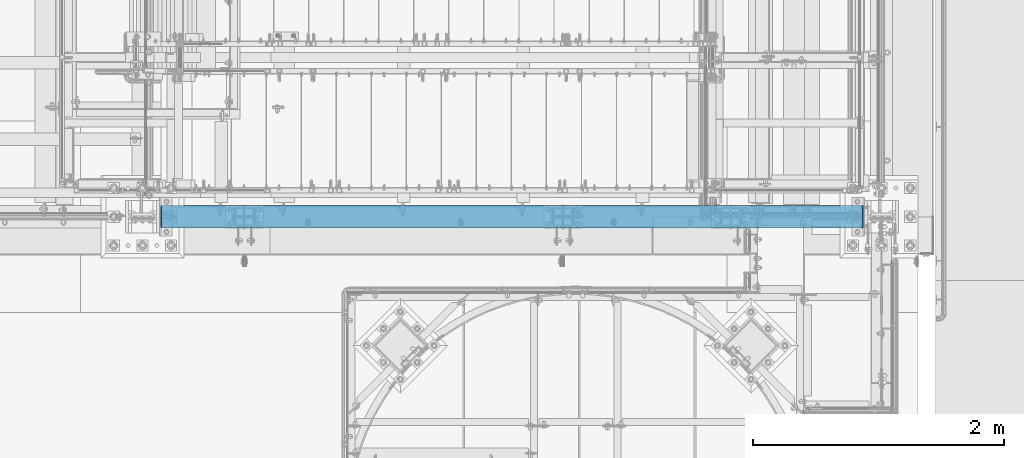
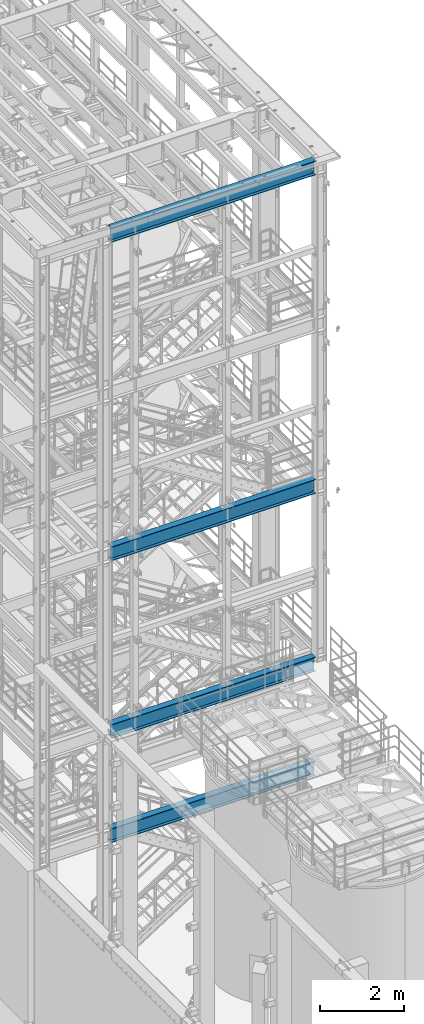
# One storey, part 945 of 1876: 4 beams, 4 elements without a shape of their own.
"""IFC2X3 building model written with IfcOpenShell, lengths in millimetres."""

from ifc_helpers import new_model, si_unit, frame, origin_with_axes, place, context, subcontext, project, spatial, faceted_brep, material, type_object, element, aggregate, save


model = new_model("IFC2X3")

# Units and contexts
model_context = context("Model", 3, precision=1e-05, world=origin_with_axes())
body_context = subcontext(model_context, "Body", "Model", "MODEL_VIEW")
ifc_project = project(units=[si_unit("LENGTHUNIT", "METRE", prefix="MILLI"), si_unit("AREAUNIT", "SQUARE_METRE"), si_unit("VOLUMEUNIT", "CUBIC_METRE"), si_unit("MASSUNIT", "GRAM", prefix="KILO"), si_unit("TIMEUNIT", "SECOND"), si_unit("PLANEANGLEUNIT", "RADIAN"), si_unit("SOLIDANGLEUNIT", "STERADIAN"), si_unit("THERMODYNAMICTEMPERATUREUNIT", "DEGREE_CELSIUS"), si_unit("LUMINOUSINTENSITYUNIT", "LUMEN")], contexts=[model_context])

# Site, building, storey
site_placement = place(None, origin_with_axes())
site = spatial("IfcSite", under=ifc_project, at=site_placement, CompositionType="ELEMENT")
building_placement = place(site_placement, origin_with_axes())
building = spatial("IfcBuilding", under=site, at=building_placement, Name="Undefined", CompositionType="ELEMENT")
storey_placement = place(building_placement, origin_with_axes())
storey = spatial("IfcBuildingStorey", under=building, at=storey_placement, Name="Undefined", CompositionType="ELEMENT", Elevation=0.0)

# Assembly, beam
assembly_1_placement = place(storey_placement, origin_with_axes())
assembly_1 = element("IfcElementAssembly", 1, at=assembly_1_placement, inside=storey, Name="BEAM", AssemblyPlace="NOTDEFINED", PredefinedType="RIGID_FRAME")
ifc_material = material(Name="STEEL/A992")
beam_type = type_object("IfcBeamType", Name="W16X45", PredefinedType="NOTDEFINED")
beam_1_placement = place(assembly_1_placement, frame((1727.2, -7112.0, 13104.8125), z_axis=(0.0, 0.0, 1.0), x_axis=(1.0, 0.0, 0.0)))
beam_1 = element("IfcBeam", 2, at=beam_1_placement, type_object=beam_type, material=ifc_material, Name="BEAM", ObjectType="W16X45", context=body_context, shape_type="Brep", body=[
    faceted_brep([(5748.3375, 4.76249999999982, 161.924999999999), (5738.81249970572, -4.76249999999982, 161.924999999999), (5738.81249970572, -4.76249999999982, -161.924999999999), (5748.3375, 4.76249999999982, -161.924999999999), (144.4625, 88.8999999999996, 190.5), (152.711099599373, 88.8999999999996, 204.787499999999), (5740.08890040063, 88.8999999999996, 204.787499999999), (5748.3375, 88.8999999999996, 190.5), (144.4625, 4.76249999999982, 190.5), (5748.3375, 4.76249999999982, 190.5), (152.711120260645, -88.8999999999996, -190.5), (144.4625, -88.8999999999996, -204.787499999999), (5748.3375, -88.8999999999996, -204.787499999999), (5740.08887973935, -88.8999999999996, -190.5), (144.4625, 88.8999999999996, -204.787499999999), (5748.3375, 88.8999999999996, -204.787499999999), (152.711120260645, 88.8999999999996, -190.5), (5740.08887973935, 88.8999999999996, -190.5), (152.711120260645, 4.76249999999982, -190.5), (5740.08887973935, 4.76249999999982, -190.5), (5696.31330732956, -4.76249999999982, -163.290718362852), (5696.31330732956, 4.76249999999982, -163.290718362852), (5701.22775003691, 4.76249999999982, -161.924999999999), (5701.22775003691, -4.76249999999982, -161.924999999999), (5692.80815489359, -4.76249999999982, -166.996233194965), (5692.80815489359, 4.76249999999982, -166.996233194965), (5691.71744784461, -4.76249999999982, -171.978932453771), (5691.71744784461, 4.76249999999982, -171.978932453771), (5693.35396281357, -4.76249999999982, -176.80995227641), (5693.35396281357, 4.76249999999982, -176.80995227641), (5697.24840454932, -4.76249999999982, -180.103925156887), (5697.24840454932, 4.76249999999982, -180.103925156887), (5718.99349932861, -4.76249999999982, -190.102999496459), (5718.99349932861, 4.76249999999982, -190.102999496459), (5739.85968949887, -4.76249999999982, -190.102999496459), (5739.85968949887, 4.76249999999982, -190.102999496459), (5740.08887973935, -4.76249999999982, -190.5), (152.711120260645, -4.76249999999982, -190.5), (152.940310501126, -4.76249999999982, -190.102999496459), (152.940310501126, 4.76249999999982, -190.102999496459), (173.806500671387, -4.76249999999982, -190.102999496459), (173.806500671387, 4.76249999999982, -190.102999496459), (195.551595450686, -4.76249999999982, -180.103925156884), (195.551595450686, 4.76249999999982, -180.103925156884), (199.446037186428, -4.76249999999982, -176.80995227641), (199.446037186428, 4.76249999999982, -176.80995227641), (201.082552155395, -4.76249999999982, -171.978932453767), (201.082552155395, 4.76249999999982, -171.978932453767), (199.991845106413, -4.76249999999982, -166.996233194965), (199.991845106413, 4.76249999999982, -166.996233194965), (196.486692670442, -4.76249999999982, -163.290718362852), (196.486692670442, 4.76249999999982, -163.290718362852), (191.572249963099, -4.76249999999982, -161.924999999999), (191.572249963099, 4.76249999999982, -161.924999999999), (153.987500294277, -4.76249999999982, -161.924999999996), (144.4625, 4.76249999999982, -161.924999999996), (153.987500294277, -4.7625002942832, 161.925000000003), (144.4625, 4.76249999999982, 161.925000000003), (190.80324988243, -4.76249999999982, 161.924999999999), (190.80324988243, 4.76249999999982, 161.924999999999), (195.717692628333, -4.76249999999982, 163.290718386077), (195.717692628333, 4.76249999999982, 163.290718386077), (199.22284506784, -4.76249999999982, 166.996233274545), (199.22284506784, 4.76249999999982, 166.996233274545), (200.313552067229, -4.76249999999982, 171.978932588601), (200.313552067229, 4.76249999999982, 171.978932588601), (198.677037004441, -4.76249999999982, 176.80995242525), (198.677037004441, 4.76249999999982, 176.80995242525), (194.782595165536, -4.76249999999982, 180.103925250914), (194.782595165536, 4.76249999999982, 180.103925250914), (173.037499237061, -4.76249999999982, 190.102999496463), (173.037499237061, 4.76249999999982, 190.102999496463), (144.4625, -4.76249999999982, 190.102999496463), (144.4625, 4.76249999999982, 190.102999496463), (144.4625, -4.76249999999982, 190.5), (152.711099599373, -88.8999999999996, 204.787499999999), (144.4625, -88.8999999999996, 190.5), (5748.3375, -4.76249999999982, 190.5), (5748.3375, -88.8999999999996, 190.5), (5740.08890040063, -88.8999999999996, 204.787499999999), (5748.3375, -4.76249999999982, 190.102999496459), (5748.3375, 4.76249999999982, 190.102999496459), (5719.76250076294, -4.76249999999982, 190.102999496459), (5719.76250076294, 4.76249999999982, 190.102999496459), (5698.01740483447, -4.76249999999982, 180.103925250914), (5698.01740483447, 4.76249999999982, 180.103925250914), (5694.12296299556, -4.76249999999982, 176.80995242525), (5694.12296299556, 4.76249999999982, 176.80995242525), (5692.48644793277, -4.76249999999982, 171.978932588601), (5692.48644793277, 4.76249999999982, 171.978932588601), (5693.57715493216, -4.76249999999982, 166.996233274542), (5693.57715493216, 4.76249999999982, 166.996233274542), (5697.08230737167, -4.76249999999982, 163.290718386077), (5697.08230737167, 4.76249999999982, 163.290718386077), (5701.99675011757, -4.76249999999982, 161.924999999999), (5701.99675011757, 4.76249999999982, 161.924999999999)], [[[0, 1, 2, 3]], [[4, 5, 6, 7]], [[8, 4, 7, 9]], [[10, 11, 12, 13]], [[11, 14, 15, 12]], [[14, 16, 17, 15]], [[16, 18, 19, 17]], [[20, 21, 22, 23]], [[24, 25, 21, 20]], [[26, 27, 25, 24]], [[28, 29, 27, 26]], [[30, 31, 29, 28]], [[32, 33, 31, 30]], [[33, 32, 34, 35]], [[12, 15, 17, 19, 35, 34, 36, 13]], [[37, 10, 13, 36]], [[38, 39, 18, 16, 14, 11, 10, 37]], [[40, 41, 39, 38]], [[42, 43, 41, 40]], [[44, 45, 43, 42]], [[46, 47, 45, 44]], [[48, 49, 47, 46]], [[50, 51, 49, 48]], [[52, 53, 51, 50]], [[53, 52, 54, 55]], [[56, 57, 55, 54]], [[58, 59, 57, 56]], [[60, 61, 59, 58]], [[62, 63, 61, 60]], [[64, 65, 63, 62]], [[66, 67, 65, 64]], [[68, 69, 67, 66]], [[70, 71, 69, 68]], [[71, 70, 72, 73]], [[73, 72, 74, 8]], [[75, 5, 4, 8, 74, 76]], [[76, 74, 77, 78]], [[75, 76, 78, 79]], [[5, 75, 79, 6]], [[78, 77, 9, 7, 6, 79]], [[80, 81, 9, 77]], [[82, 83, 81, 80]], [[84, 85, 83, 82]], [[86, 87, 85, 84]], [[88, 89, 87, 86]], [[90, 91, 89, 88]], [[92, 93, 91, 90]], [[94, 95, 93, 92]], [[22, 21, 25, 27, 29, 31, 33, 35, 19, 18, 39, 41, 43, 45, 47, 49, 51, 53, 55, 57, 59, 61, 63, 65, 67, 69, 71, 73, 8, 9, 81, 83, 85, 87, 89, 91, 93, 95, 0, 3]], [[23, 22, 3, 2]], [[94, 92, 90, 88, 86, 84, 82, 80, 77, 74, 72, 70, 68, 66, 64, 62, 60, 58, 56, 54, 52, 50, 48, 46, 44, 42, 40, 38, 37, 36, 34, 32, 30, 28, 26, 24, 20, 23, 2, 1]], [[95, 94, 1, 0]]]),
])
aggregate(assembly_1, [beam_1])

assembly_2_placement = place(storey_placement, origin_with_axes())
assembly_2 = element("IfcElementAssembly", 3, at=assembly_2_placement, inside=storey, Name="BEAM", AssemblyPlace="NOTDEFINED", PredefinedType="RIGID_FRAME")
beam_2_placement = place(assembly_2_placement, frame((1727.2, -7112.0, 7948.6125), z_axis=(0.0, 0.0, 1.0), x_axis=(1.0, 0.0, 0.0)))
beam_2 = element("IfcBeam", 4, at=beam_2_placement, type_object=beam_type, material=ifc_material, Name="BEAM", ObjectType="W16X45", context=body_context, shape_type="Brep", body=[
    faceted_brep([(5748.3375, 4.76249999999982, 161.924999999999), (5738.81249970572, -4.76249999999982, 161.924999999999), (5738.81249970572, -4.76249999999982, -161.924999999999), (5748.3375, 4.76249999999982, -161.924999999999), (144.4625, 88.8999999999996, 190.5), (152.711099599373, 88.8999999999996, 204.787499999999), (5740.08890040063, 88.8999999999996, 204.787499999999), (5748.3375, 88.8999999999996, 190.5), (144.4625, 4.76249999999982, 190.5), (5748.3375, 4.76249999999982, 190.5), (152.711120260645, -88.8999999999996, -190.5), (144.4625, -88.8999999999996, -204.787499999999), (5748.3375, -88.8999999999996, -204.787499999999), (5740.08887973935, -88.8999999999996, -190.5), (144.4625, 88.8999999999996, -204.787499999999), (5748.3375, 88.8999999999996, -204.787499999999), (152.711120260645, 88.8999999999996, -190.5), (5740.08887973935, 88.8999999999996, -190.5), (152.711120260645, 4.76249999999982, -190.5), (5740.08887973935, 4.76249999999982, -190.5), (5696.31330732956, -4.76249999999982, -163.290718362852), (5696.31330732956, 4.76249999999982, -163.290718362852), (5701.22775003691, 4.76249999999982, -161.924999999999), (5701.22775003691, -4.76249999999982, -161.924999999999), (5692.80815489359, -4.76249999999982, -166.996233194965), (5692.80815489359, 4.76249999999982, -166.996233194965), (5691.71744784461, -4.76249999999982, -171.978932453771), (5691.71744784461, 4.76249999999982, -171.978932453771), (5693.35396281357, -4.76249999999982, -176.80995227641), (5693.35396281357, 4.76249999999982, -176.80995227641), (5697.24840454932, -4.76249999999982, -180.103925156887), (5697.24840454932, 4.76249999999982, -180.103925156887), (5718.99349932861, -4.76249999999982, -190.102999496459), (5718.99349932861, 4.76249999999982, -190.102999496459), (5739.85968949887, -4.76249999999982, -190.102999496459), (5739.85968949887, 4.76249999999982, -190.102999496459), (5740.08887973935, -4.76249999999982, -190.5), (152.711120260645, -4.76249999999982, -190.5), (152.940310501126, -4.76249999999982, -190.102999496459), (152.940310501126, 4.76249999999982, -190.102999496459), (173.806500671387, -4.76249999999982, -190.102999496459), (173.806500671387, 4.76249999999982, -190.102999496459), (195.551595450686, -4.76249999999982, -180.103925156884), (195.551595450686, 4.76249999999982, -180.103925156884), (199.446037186428, -4.76249999999982, -176.80995227641), (199.446037186428, 4.76249999999982, -176.80995227641), (201.082552155395, -4.76249999999982, -171.978932453767), (201.082552155395, 4.76249999999982, -171.978932453767), (199.991845106413, -4.76249999999982, -166.996233194965), (199.991845106413, 4.76249999999982, -166.996233194965), (196.486692670442, -4.76249999999982, -163.290718362852), (196.486692670442, 4.76249999999982, -163.290718362852), (191.572249963099, -4.76249999999982, -161.924999999999), (191.572249963099, 4.76249999999982, -161.924999999999), (153.987500294277, -4.76249999999982, -161.924999999996), (144.4625, 4.76249999999982, -161.924999999996), (153.987500294277, -4.7625002942832, 161.925000000003), (144.4625, 4.76249999999982, 161.925000000003), (190.80324988243, -4.76249999999982, 161.924999999999), (190.80324988243, 4.76249999999982, 161.924999999999), (195.717692628333, -4.76249999999982, 163.290718386077), (195.717692628333, 4.76249999999982, 163.290718386077), (199.22284506784, -4.76249999999982, 166.996233274545), (199.22284506784, 4.76249999999982, 166.996233274545), (200.313552067229, -4.76249999999982, 171.978932588601), (200.313552067229, 4.76249999999982, 171.978932588601), (198.677037004441, -4.76249999999982, 176.80995242525), (198.677037004441, 4.76249999999982, 176.80995242525), (194.782595165536, -4.76249999999982, 180.103925250914), (194.782595165536, 4.76249999999982, 180.103925250914), (173.037499237061, -4.76249999999982, 190.102999496463), (173.037499237061, 4.76249999999982, 190.102999496463), (144.4625, -4.76249999999982, 190.102999496463), (144.4625, 4.76249999999982, 190.102999496463), (144.4625, -4.76249999999982, 190.5), (152.711099599373, -88.8999999999996, 204.787499999999), (144.4625, -88.8999999999996, 190.5), (5748.3375, -4.76249999999982, 190.5), (5748.3375, -88.8999999999996, 190.5), (5740.08890040063, -88.8999999999996, 204.787499999999), (5748.3375, -4.76249999999982, 190.102999496459), (5748.3375, 4.76249999999982, 190.102999496459), (5719.76250076294, -4.76249999999982, 190.102999496459), (5719.76250076294, 4.76249999999982, 190.102999496459), (5698.01740483447, -4.76249999999982, 180.103925250914), (5698.01740483447, 4.76249999999982, 180.103925250914), (5694.12296299556, -4.76249999999982, 176.80995242525), (5694.12296299556, 4.76249999999982, 176.80995242525), (5692.48644793277, -4.76249999999982, 171.978932588601), (5692.48644793277, 4.76249999999982, 171.978932588601), (5693.57715493216, -4.76249999999982, 166.996233274542), (5693.57715493216, 4.76249999999982, 166.996233274542), (5697.08230737167, -4.76249999999982, 163.290718386077), (5697.08230737167, 4.76249999999982, 163.290718386077), (5701.99675011757, -4.76249999999982, 161.924999999999), (5701.99675011757, 4.76249999999982, 161.924999999999)], [[[0, 1, 2, 3]], [[4, 5, 6, 7]], [[8, 4, 7, 9]], [[10, 11, 12, 13]], [[11, 14, 15, 12]], [[14, 16, 17, 15]], [[16, 18, 19, 17]], [[20, 21, 22, 23]], [[24, 25, 21, 20]], [[26, 27, 25, 24]], [[28, 29, 27, 26]], [[30, 31, 29, 28]], [[32, 33, 31, 30]], [[33, 32, 34, 35]], [[12, 15, 17, 19, 35, 34, 36, 13]], [[37, 10, 13, 36]], [[38, 39, 18, 16, 14, 11, 10, 37]], [[40, 41, 39, 38]], [[42, 43, 41, 40]], [[44, 45, 43, 42]], [[46, 47, 45, 44]], [[48, 49, 47, 46]], [[50, 51, 49, 48]], [[52, 53, 51, 50]], [[53, 52, 54, 55]], [[56, 57, 55, 54]], [[58, 59, 57, 56]], [[60, 61, 59, 58]], [[62, 63, 61, 60]], [[64, 65, 63, 62]], [[66, 67, 65, 64]], [[68, 69, 67, 66]], [[70, 71, 69, 68]], [[71, 70, 72, 73]], [[73, 72, 74, 8]], [[75, 5, 4, 8, 74, 76]], [[76, 74, 77, 78]], [[75, 76, 78, 79]], [[5, 75, 79, 6]], [[78, 77, 9, 7, 6, 79]], [[80, 81, 9, 77]], [[82, 83, 81, 80]], [[84, 85, 83, 82]], [[86, 87, 85, 84]], [[88, 89, 87, 86]], [[90, 91, 89, 88]], [[92, 93, 91, 90]], [[94, 95, 93, 92]], [[22, 21, 25, 27, 29, 31, 33, 35, 19, 18, 39, 41, 43, 45, 47, 49, 51, 53, 55, 57, 59, 61, 63, 65, 67, 69, 71, 73, 8, 9, 81, 83, 85, 87, 89, 91, 93, 95, 0, 3]], [[23, 22, 3, 2]], [[94, 92, 90, 88, 86, 84, 82, 80, 77, 74, 72, 70, 68, 66, 64, 62, 60, 58, 56, 54, 52, 50, 48, 46, 44, 42, 40, 38, 37, 36, 34, 32, 30, 28, 26, 24, 20, 23, 2, 1]], [[95, 94, 1, 0]]]),
])
aggregate(assembly_2, [beam_2])

assembly_3_placement = place(storey_placement, origin_with_axes())
assembly_3 = element("IfcElementAssembly", 5, at=assembly_3_placement, inside=storey, Name="BEAM", AssemblyPlace="NOTDEFINED", PredefinedType="RIGID_FRAME")
beam_3_placement = place(assembly_3_placement, frame((1727.2, -7112.0, 22350.4125), z_axis=(0.0, 0.0, 1.0), x_axis=(1.0, 0.0, 0.0)))
beam_3 = element("IfcBeam", 6, at=beam_3_placement, type_object=beam_type, material=ifc_material, Name="BEAM", ObjectType="W16X45", context=body_context, shape_type="Brep", body=[
    faceted_brep([(5748.3375, 4.76249999999982, 161.924999999999), (5738.81249970572, -4.76249999999982, 161.924999999999), (5738.81249970572, -4.76249999999982, -161.924999999999), (5748.3375, 4.76249999999982, -161.924999999999), (144.4625, 88.8999999999996, 190.5), (152.711099599373, 88.8999999999996, 204.787499999999), (5740.08890040063, 88.8999999999996, 204.787499999999), (5748.3375, 88.8999999999996, 190.5), (144.4625, 4.76249999999982, 190.5), (5748.3375, 4.76249999999982, 190.5), (152.711120260645, -88.8999999999996, -190.5), (144.4625, -88.8999999999996, -204.787499999999), (5748.3375, -88.8999999999996, -204.787499999999), (5740.08887973935, -88.8999999999996, -190.5), (144.4625, 88.8999999999996, -204.787499999999), (5748.3375, 88.8999999999996, -204.787499999999), (152.711120260645, 88.8999999999996, -190.5), (5740.08887973935, 88.8999999999996, -190.5), (152.711120260645, 4.76249999999982, -190.5), (5740.08887973935, 4.76249999999982, -190.5), (5696.31330732956, -4.76249999999982, -163.290718362852), (5696.31330732956, 4.76249999999982, -163.290718362852), (5701.22775003691, 4.76249999999982, -161.924999999999), (5701.22775003691, -4.76249999999982, -161.924999999999), (5692.80815489359, -4.76249999999982, -166.996233194965), (5692.80815489359, 4.76249999999982, -166.996233194965), (5691.71744784461, -4.76249999999982, -171.978932453771), (5691.71744784461, 4.76249999999982, -171.978932453771), (5693.35396281357, -4.76249999999982, -176.80995227641), (5693.35396281357, 4.76249999999982, -176.80995227641), (5697.24840454932, -4.76249999999982, -180.103925156887), (5697.24840454932, 4.76249999999982, -180.103925156887), (5718.99349932861, -4.76249999999982, -190.102999496459), (5718.99349932861, 4.76249999999982, -190.102999496459), (5739.85968949887, -4.76249999999982, -190.102999496459), (5739.85968949887, 4.76249999999982, -190.102999496459), (5740.08887973935, -4.76249999999982, -190.5), (152.711120260645, -4.76249999999982, -190.5), (152.940310501126, -4.76249999999982, -190.102999496459), (152.940310501126, 4.76249999999982, -190.102999496459), (173.806500671387, -4.76249999999982, -190.102999496459), (173.806500671387, 4.76249999999982, -190.102999496459), (195.551595450686, -4.76249999999982, -180.103925156884), (195.551595450686, 4.76249999999982, -180.103925156884), (199.446037186428, -4.76249999999982, -176.80995227641), (199.446037186428, 4.76249999999982, -176.80995227641), (201.082552155395, -4.76249999999982, -171.978932453767), (201.082552155395, 4.76249999999982, -171.978932453767), (199.991845106413, -4.76249999999982, -166.996233194965), (199.991845106413, 4.76249999999982, -166.996233194965), (196.486692670442, -4.76249999999982, -163.290718362852), (196.486692670442, 4.76249999999982, -163.290718362852), (191.572249963099, -4.76249999999982, -161.924999999999), (191.572249963099, 4.76249999999982, -161.924999999999), (153.987500294277, -4.76249999999982, -161.924999999996), (144.4625, 4.76249999999982, -161.924999999996), (153.987500294277, -4.7625002942832, 161.925000000003), (144.4625, 4.76249999999982, 161.925000000003), (190.80324988243, -4.76249999999982, 161.924999999999), (190.80324988243, 4.76249999999982, 161.924999999999), (195.717692628333, -4.76249999999982, 163.290718386077), (195.717692628333, 4.76249999999982, 163.290718386077), (199.22284506784, -4.76249999999982, 166.996233274545), (199.22284506784, 4.76249999999982, 166.996233274545), (200.313552067229, -4.76249999999982, 171.978932588601), (200.313552067229, 4.76249999999982, 171.978932588601), (198.677037004441, -4.76249999999982, 176.80995242525), (198.677037004441, 4.76249999999982, 176.80995242525), (194.782595165536, -4.76249999999982, 180.103925250914), (194.782595165536, 4.76249999999982, 180.103925250914), (173.037499237061, -4.76249999999982, 190.102999496463), (173.037499237061, 4.76249999999982, 190.102999496463), (144.4625, -4.76249999999982, 190.102999496463), (144.4625, 4.76249999999982, 190.102999496463), (144.4625, -4.76249999999982, 190.5), (152.711099599373, -88.8999999999996, 204.787499999999), (144.4625, -88.8999999999996, 190.5), (5748.3375, -4.76249999999982, 190.5), (5748.3375, -88.8999999999996, 190.5), (5740.08890040063, -88.8999999999996, 204.787499999999), (5748.3375, -4.76249999999982, 190.102999496459), (5748.3375, 4.76249999999982, 190.102999496459), (5719.76250076294, -4.76249999999982, 190.102999496459), (5719.76250076294, 4.76249999999982, 190.102999496459), (5698.01740483447, -4.76249999999982, 180.103925250914), (5698.01740483447, 4.76249999999982, 180.103925250914), (5694.12296299556, -4.76249999999982, 176.80995242525), (5694.12296299556, 4.76249999999982, 176.80995242525), (5692.48644793277, -4.76249999999982, 171.978932588601), (5692.48644793277, 4.76249999999982, 171.978932588601), (5693.57715493216, -4.76249999999982, 166.996233274542), (5693.57715493216, 4.76249999999982, 166.996233274542), (5697.08230737167, -4.76249999999982, 163.290718386077), (5697.08230737167, 4.76249999999982, 163.290718386077), (5701.99675011757, -4.76249999999982, 161.924999999999), (5701.99675011757, 4.76249999999982, 161.924999999999)], [[[0, 1, 2, 3]], [[4, 5, 6, 7]], [[8, 4, 7, 9]], [[10, 11, 12, 13]], [[11, 14, 15, 12]], [[14, 16, 17, 15]], [[16, 18, 19, 17]], [[20, 21, 22, 23]], [[24, 25, 21, 20]], [[26, 27, 25, 24]], [[28, 29, 27, 26]], [[30, 31, 29, 28]], [[32, 33, 31, 30]], [[33, 32, 34, 35]], [[12, 15, 17, 19, 35, 34, 36, 13]], [[37, 10, 13, 36]], [[38, 39, 18, 16, 14, 11, 10, 37]], [[40, 41, 39, 38]], [[42, 43, 41, 40]], [[44, 45, 43, 42]], [[46, 47, 45, 44]], [[48, 49, 47, 46]], [[50, 51, 49, 48]], [[52, 53, 51, 50]], [[53, 52, 54, 55]], [[56, 57, 55, 54]], [[58, 59, 57, 56]], [[60, 61, 59, 58]], [[62, 63, 61, 60]], [[64, 65, 63, 62]], [[66, 67, 65, 64]], [[68, 69, 67, 66]], [[70, 71, 69, 68]], [[71, 70, 72, 73]], [[73, 72, 74, 8]], [[75, 5, 4, 8, 74, 76]], [[76, 74, 77, 78]], [[75, 76, 78, 79]], [[5, 75, 79, 6]], [[78, 77, 9, 7, 6, 79]], [[80, 81, 9, 77]], [[82, 83, 81, 80]], [[84, 85, 83, 82]], [[86, 87, 85, 84]], [[88, 89, 87, 86]], [[90, 91, 89, 88]], [[92, 93, 91, 90]], [[94, 95, 93, 92]], [[22, 21, 25, 27, 29, 31, 33, 35, 19, 18, 39, 41, 43, 45, 47, 49, 51, 53, 55, 57, 59, 61, 63, 65, 67, 69, 71, 73, 8, 9, 81, 83, 85, 87, 89, 91, 93, 95, 0, 3]], [[23, 22, 3, 2]], [[94, 92, 90, 88, 86, 84, 82, 80, 77, 74, 72, 70, 68, 66, 64, 62, 60, 58, 56, 54, 52, 50, 48, 46, 44, 42, 40, 38, 37, 36, 34, 32, 30, 28, 26, 24, 20, 23, 2, 1]], [[95, 94, 1, 0]]]),
])
aggregate(assembly_3, [beam_3])

assembly_4_placement = place(storey_placement, origin_with_axes())
assembly_4 = element("IfcElementAssembly", 7, at=assembly_4_placement, inside=storey, Name="BEAM", AssemblyPlace="NOTDEFINED", PredefinedType="RIGID_FRAME")
beam_4_placement = place(assembly_4_placement, frame((1727.2, -7112.0, 4926.0125), z_axis=(0.0, 0.0, 1.0), x_axis=(1.0, 0.0, 0.0)))
beam_4 = element("IfcBeam", 8, at=beam_4_placement, type_object=beam_type, material=ifc_material, Name="BEAM", ObjectType="W16X45", context=body_context, shape_type="Brep", body=[
    faceted_brep([(5748.3375, 4.76249999999982, 161.924999999999), (5738.81249970572, -4.76249999999982, 161.924999999999), (5738.81249970572, -4.76249999999982, -161.924999999999), (5748.3375, 4.76249999999982, -161.924999999999), (144.4625, 88.8999999999996, 190.5), (152.711099599373, 88.8999999999996, 204.787499999999), (5740.08890040063, 88.8999999999996, 204.787499999999), (5748.3375, 88.8999999999996, 190.5), (144.4625, 4.76249999999982, 190.5), (5748.3375, 4.76249999999982, 190.5), (152.711120260645, -88.8999999999996, -190.5), (144.4625, -88.8999999999996, -204.787499999999), (5748.3375, -88.8999999999996, -204.787499999999), (5740.08887973935, -88.8999999999996, -190.5), (144.4625, 88.8999999999996, -204.787499999999), (5748.3375, 88.8999999999996, -204.787499999999), (152.711120260645, 88.8999999999996, -190.5), (5740.08887973935, 88.8999999999996, -190.5), (152.711120260645, 4.76249999999982, -190.5), (5740.08887973935, 4.76249999999982, -190.5), (5696.31330732956, -4.76249999999982, -163.290718362852), (5696.31330732956, 4.76249999999982, -163.290718362852), (5701.22775003691, 4.76249999999982, -161.924999999999), (5701.22775003691, -4.76249999999982, -161.924999999999), (5692.80815489359, -4.76249999999982, -166.996233194965), (5692.80815489359, 4.76249999999982, -166.996233194965), (5691.71744784461, -4.76249999999982, -171.978932453771), (5691.71744784461, 4.76249999999982, -171.978932453771), (5693.35396281357, -4.76249999999982, -176.80995227641), (5693.35396281357, 4.76249999999982, -176.80995227641), (5697.24840454932, -4.76249999999982, -180.103925156887), (5697.24840454932, 4.76249999999982, -180.103925156887), (5718.99349932861, -4.76249999999982, -190.102999496459), (5718.99349932861, 4.76249999999982, -190.102999496459), (5739.85968949887, -4.76249999999982, -190.102999496459), (5739.85968949887, 4.76249999999982, -190.102999496459), (5740.08887973935, -4.76249999999982, -190.5), (152.711120260645, -4.76249999999982, -190.5), (152.940310501126, -4.76249999999982, -190.102999496459), (152.940310501126, 4.76249999999982, -190.102999496459), (173.806500671387, -4.76249999999982, -190.102999496459), (173.806500671387, 4.76249999999982, -190.102999496459), (195.551595450686, -4.76249999999982, -180.103925156884), (195.551595450686, 4.76249999999982, -180.103925156884), (199.446037186428, -4.76249999999982, -176.80995227641), (199.446037186428, 4.76249999999982, -176.80995227641), (201.082552155395, -4.76249999999982, -171.978932453767), (201.082552155395, 4.76249999999982, -171.978932453767), (199.991845106413, -4.76249999999982, -166.996233194965), (199.991845106413, 4.76249999999982, -166.996233194965), (196.486692670442, -4.76249999999982, -163.290718362852), (196.486692670442, 4.76249999999982, -163.290718362852), (191.572249963099, -4.76249999999982, -161.924999999999), (191.572249963099, 4.76249999999982, -161.924999999999), (153.987500294277, -4.76249999999982, -161.924999999996), (144.4625, 4.76249999999982, -161.924999999996), (153.987500294277, -4.7625002942832, 161.925000000003), (144.4625, 4.76249999999982, 161.925000000003), (190.80324988243, -4.76249999999982, 161.924999999999), (190.80324988243, 4.76249999999982, 161.924999999999), (195.717692628333, -4.76249999999982, 163.290718386077), (195.717692628333, 4.76249999999982, 163.290718386077), (199.22284506784, -4.76249999999982, 166.996233274545), (199.22284506784, 4.76249999999982, 166.996233274545), (200.313552067229, -4.76249999999982, 171.978932588601), (200.313552067229, 4.76249999999982, 171.978932588601), (198.677037004441, -4.76249999999982, 176.80995242525), (198.677037004441, 4.76249999999982, 176.80995242525), (194.782595165536, -4.76249999999982, 180.103925250914), (194.782595165536, 4.76249999999982, 180.103925250914), (173.037499237061, -4.76249999999982, 190.102999496463), (173.037499237061, 4.76249999999982, 190.102999496463), (144.4625, -4.76249999999982, 190.102999496463), (144.4625, 4.76249999999982, 190.102999496463), (144.4625, -4.76249999999982, 190.5), (152.711099599373, -88.8999999999996, 204.787499999999), (144.4625, -88.8999999999996, 190.5), (5748.3375, -88.8999999999996, 190.5), (5740.08890040063, -88.8999999999996, 204.787499999999), (5748.3375, -4.76249999999982, 190.5), (5748.3375, -4.76249999999982, 190.102999496459), (5748.3375, 4.76249999999982, 190.102999496459), (5719.76250076294, -4.76249999999982, 190.102999496459), (5719.76250076294, 4.76249999999982, 190.102999496459), (5698.01740483447, -4.76249999999982, 180.103925250914), (5698.01740483447, 4.76249999999982, 180.103925250914), (5694.12296299556, -4.76249999999982, 176.80995242525), (5694.12296299556, 4.76249999999982, 176.80995242525), (5692.48644793277, -4.76249999999982, 171.978932588601), (5692.48644793277, 4.76249999999982, 171.978932588601), (5693.57715493216, -4.76249999999982, 166.996233274542), (5693.57715493216, 4.76249999999982, 166.996233274542), (5697.08230737167, -4.76249999999982, 163.290718386077), (5697.08230737167, 4.76249999999982, 163.290718386077), (5701.99675011757, -4.76249999999982, 161.924999999999), (5701.99675011757, 4.76249999999982, 161.924999999999)], [[[0, 1, 2, 3]], [[4, 5, 6, 7]], [[8, 4, 7, 9]], [[10, 11, 12, 13]], [[11, 14, 15, 12]], [[14, 16, 17, 15]], [[16, 18, 19, 17]], [[20, 21, 22, 23]], [[24, 25, 21, 20]], [[26, 27, 25, 24]], [[28, 29, 27, 26]], [[30, 31, 29, 28]], [[32, 33, 31, 30]], [[33, 32, 34, 35]], [[12, 15, 17, 19, 35, 34, 36, 13]], [[37, 10, 13, 36]], [[38, 39, 18, 16, 14, 11, 10, 37]], [[40, 41, 39, 38]], [[42, 43, 41, 40]], [[44, 45, 43, 42]], [[46, 47, 45, 44]], [[48, 49, 47, 46]], [[50, 51, 49, 48]], [[52, 53, 51, 50]], [[53, 52, 54, 55]], [[56, 57, 55, 54]], [[58, 59, 57, 56]], [[60, 61, 59, 58]], [[62, 63, 61, 60]], [[64, 65, 63, 62]], [[66, 67, 65, 64]], [[68, 69, 67, 66]], [[70, 71, 69, 68]], [[71, 70, 72, 73]], [[73, 72, 74, 8]], [[75, 76, 77, 78]], [[76, 74, 79, 77]], [[75, 5, 4, 8, 74, 76]], [[5, 75, 78, 6]], [[77, 79, 9, 7, 6, 78]], [[80, 81, 9, 79]], [[82, 83, 81, 80]], [[84, 85, 83, 82]], [[86, 87, 85, 84]], [[88, 89, 87, 86]], [[90, 91, 89, 88]], [[92, 93, 91, 90]], [[94, 95, 93, 92]], [[22, 21, 25, 27, 29, 31, 33, 35, 19, 18, 39, 41, 43, 45, 47, 49, 51, 53, 55, 57, 59, 61, 63, 65, 67, 69, 71, 73, 8, 9, 81, 83, 85, 87, 89, 91, 93, 95, 0, 3]], [[23, 22, 3, 2]], [[94, 92, 90, 88, 86, 84, 82, 80, 79, 74, 72, 70, 68, 66, 64, 62, 60, 58, 56, 54, 52, 50, 48, 46, 44, 42, 40, 38, 37, 36, 34, 32, 30, 28, 26, 24, 20, 23, 2, 1]], [[95, 94, 1, 0]]]),
])
aggregate(assembly_4, [beam_4])

save(model, "model.ifc")
